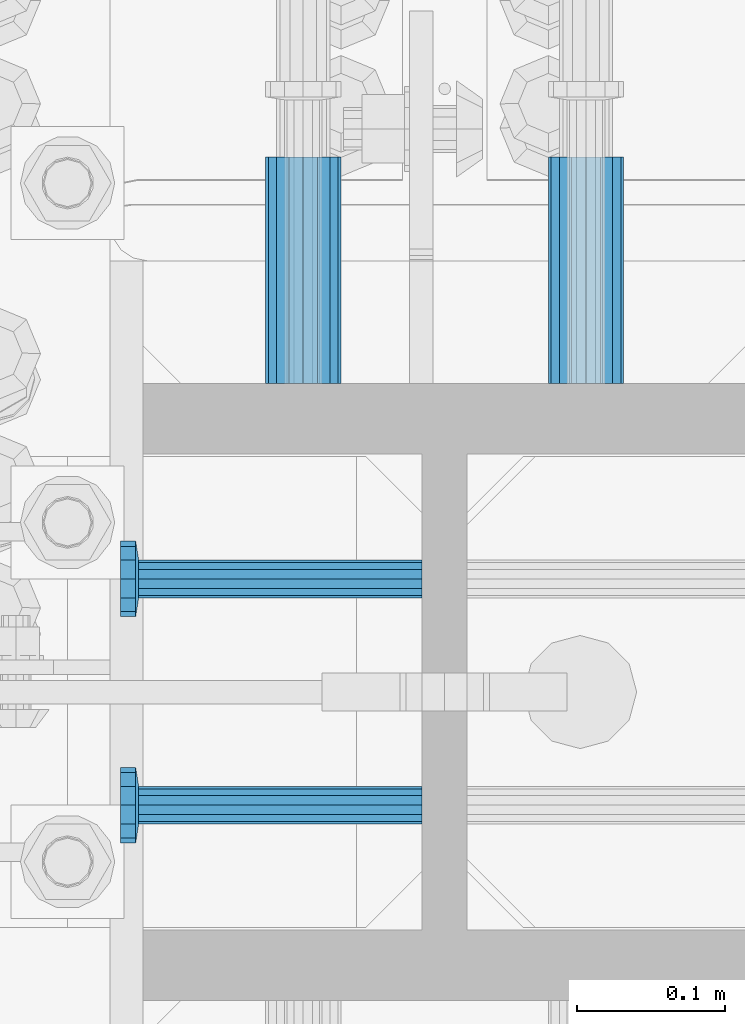
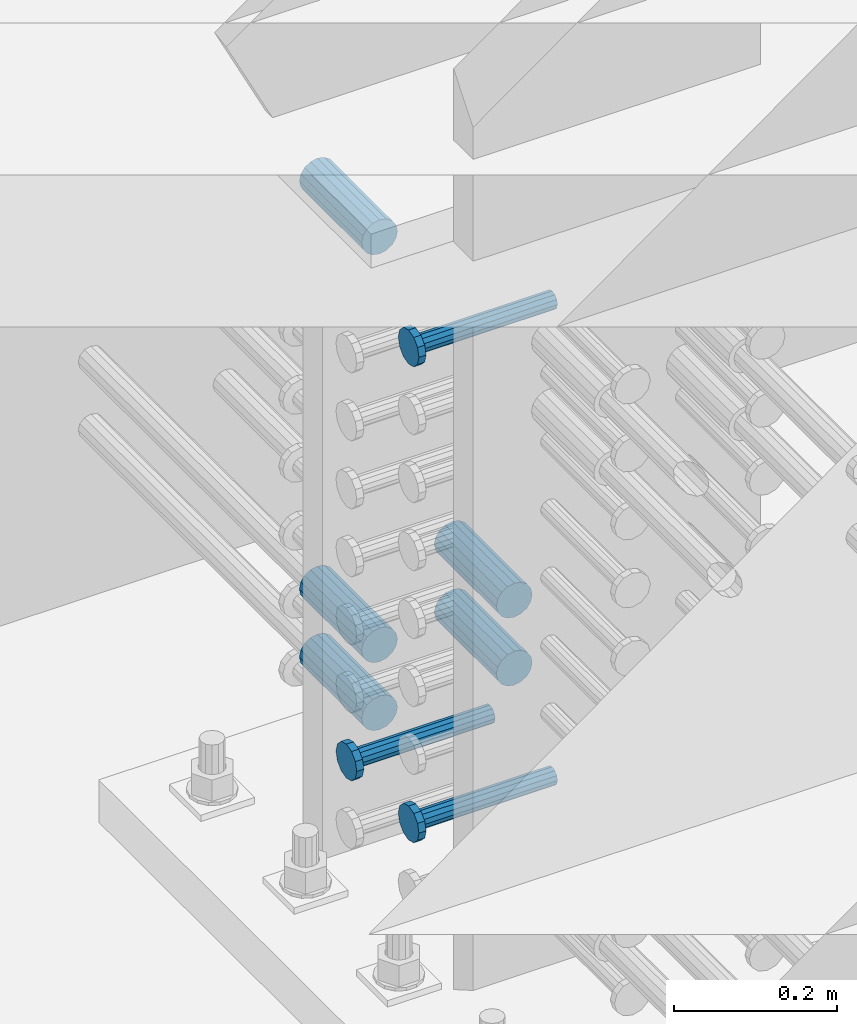
# One storey, part 1291 of 1763: 8 beams, 1 element without a shape of its own.
"""IFC2X3 building model written with IfcOpenShell, lengths in millimetres."""

import ifcopenshell
import ifcopenshell.guid

model = None  # the IFC model being written
_history = None  # IfcOwnerHistory: only IFC2X3 demands one
_inside = {}  # id of a spatial element -> (the spatial element, [elements in it])
_under = {}  # id of a project, library or spatial element -> (it, [spatial elements below it])
_declared = {}  # id of a project -> (the project, [libraries it declares])
_typed = {}  # id of a type object -> (the type object, [elements of that type])
_made_of = {}  # id of a material, layer set ... -> (it, [elements and type objects made of it])


def new_model(schema):
    """Start an empty IFC model of exactly this schema.

    Asked for "IFC4X3", IfcOpenShell would pick the latest addendum, in which some entities
    have other attributes; the version numbers below select the first issue.
    IFC2X3 requires an IfcOwnerHistory on every rooted entity: one is made here for all.
    """
    global model, _history
    if schema == "IFC4X3":
        model = ifcopenshell.file(schema_version=(4, 3, 0, 0))
    else:
        model = ifcopenshell.file(schema=schema)
    _inside.clear()
    _under.clear()
    _declared.clear()
    _typed.clear()
    _made_of.clear()
    _history = None
    if model.schema == "IFC2X3":
        org = make("IfcOrganization", Name="unknown")
        user = make(
            "IfcPersonAndOrganization",
            ThePerson=make("IfcPerson", FamilyName="unknown"),
            TheOrganization=org,
        )
        app = make(
            "IfcApplication",
            ApplicationDeveloper=org,
            Version="unknown",
            ApplicationFullName="unknown",
            ApplicationIdentifier="unknown",
        )
        _history = make(
            "IfcOwnerHistory",
            OwningUser=user,
            OwningApplication=app,
            ChangeAction="ADDED",
            CreationDate=0,
        )
    return model


def make(cls, **values):
    """One entity of the class cls with the attributes given. An attribute that is None is left unset."""
    return model.create_entity(
        cls, **{name: value for name, value in values.items() if value is not None}
    )


def rooted(cls, **values):
    """An entity with a GlobalId (a new one), such as an element, a storey or a relation."""
    return make(cls, GlobalId=ifcopenshell.guid.new(), OwnerHistory=_history, **values)


def si_unit(unit_type, name, prefix=None):
    """IfcSIUnit, for example si_unit("LENGTHUNIT", "METRE", prefix="MILLI")."""
    return make("IfcSIUnit", UnitType=unit_type, Prefix=prefix, Name=name)


def assignment(units):
    """IfcUnitAssignment: the units of a project."""
    return None if units is None else make("IfcUnitAssignment", Units=units)


def point(xyz):
    """IfcCartesianPoint."""
    return None if xyz is None else make("IfcCartesianPoint", Coordinates=xyz)


def direction(xyz):
    """IfcDirection."""
    return None if xyz is None else make("IfcDirection", DirectionRatios=xyz)


def frame(location, z_axis=None, x_axis=None):
    """IfcAxis2Placement3D, a coordinate frame: its origin and axes. An axis left out is left unset."""
    return make(
        "IfcAxis2Placement3D",
        Location=point(location),
        Axis=direction(z_axis),
        RefDirection=direction(x_axis),
    )


def origin_with_axes():
    """The frame at (0, 0, 0) with the z axis (0, 0, 1) and the x axis (1, 0, 0) written out."""
    return frame((0.0, 0.0, 0.0), z_axis=(0.0, 0.0, 1.0), x_axis=(1.0, 0.0, 0.0))


def place(relative_to, where):
    """IfcLocalPlacement: puts the frame where relative to a parent placement (None: the world)."""
    return make(
        "IfcLocalPlacement", PlacementRelTo=relative_to, RelativePlacement=where
    )


def context(
    kind, dimensions, precision=None, world=None, true_north=None, identifier=None
):
    """IfcGeometricRepresentationContext, for example the 3D "Model" context."""
    return make(
        "IfcGeometricRepresentationContext",
        ContextIdentifier=identifier,
        ContextType=kind,
        CoordinateSpaceDimension=dimensions,
        Precision=precision,
        WorldCoordinateSystem=world,
        TrueNorth=true_north,
    )


def subcontext(parent, identifier, kind, view, scale=None):
    """IfcGeometricRepresentationSubContext, for example "Body" below "Model"."""
    return make(
        "IfcGeometricRepresentationSubContext",
        ContextIdentifier=identifier,
        ContextType=kind,
        ParentContext=parent,
        TargetScale=scale,
        TargetView=view,
    )


def project(units=None, contexts=None):
    """IfcProject with its units and contexts."""
    return rooted(
        "IfcProject",
        Name="project",
        RepresentationContexts=contexts,
        UnitsInContext=assignment(units),
    )


def spatial(cls, under=None, at=None, **own):
    """A site, building, storey or space (cls), placed at a placement, below another one or the project."""
    s = rooted(cls, ObjectPlacement=at, **own)
    if under is not None:
        _under.setdefault(under.id(), (under, []))[1].append(s)
    return s


def faces_of(points, faces, orient=None, outer=None):
    """IfcFace entities. A face is a list of loops; a loop is a list of indices into points, from 0.

    orient and outer hold one flag for each loop. By default every Orientation is true, the
    first loop of a face is its IfcFaceOuterBound and the others are IfcFaceBound.
    """
    made = []
    for i, loops in enumerate(faces):
        bounds = []
        for j, loop in enumerate(loops):
            is_outer = j == 0 if outer is None else outer[i][j]
            bounds.append(
                make(
                    "IfcFaceOuterBound" if is_outer else "IfcFaceBound",
                    Bound=make("IfcPolyLoop", Polygon=[points[k] for k in loop]),
                    Orientation=True if orient is None else orient[i][j],
                )
            )
        made.append(make("IfcFace", Bounds=bounds))
    return made


def faceted_brep(points, faces, orient=None, outer=None, voids=None):
    """IfcFacetedBrep: a solid bounded by flat faces; with voids (closed shells), ...WithVoids."""
    shared = [point(p) for p in points]
    hull = make("IfcClosedShell", CfsFaces=faces_of(shared, faces, orient, outer))
    if voids is None:
        return make("IfcFacetedBrep", Outer=hull)
    return make(
        "IfcFacetedBrepWithVoids",
        Outer=hull,
        Voids=[
            make(cls, CfsFaces=faces_of(shared, fs, o, b)) for cls, fs, o, b in voids
        ],
    )


def shape(context_of_items, identifier, shape_type, items):
    """IfcShapeRepresentation: the items that make up one representation, for example the "Body"."""
    return make(
        "IfcShapeRepresentation",
        ContextOfItems=context_of_items,
        RepresentationIdentifier=identifier,
        RepresentationType=shape_type,
        Items=items,
    )


def material(Name=None, Category=None):
    """IfcMaterial."""
    return make("IfcMaterial", Name=Name, Category=Category)


def made_of(thing, what):
    """Note that an element or type object is made of a material, layer set ...; save() writes the relation."""
    if what is not None:
        _made_of.setdefault(what.id(), (what, []))[1].append(thing)
    return thing


def type_object(cls, material=None, **own):
    """A type object (cls), such as IfcWallType, which elements share."""
    return made_of(rooted(cls, **own), material)


def element(
    cls,
    number,
    at=None,
    inside=None,
    cuts=None,
    type_object=None,
    material=None,
    context=None,
    identifier="Body",
    shape_type=None,
    held_by="IfcProductDefinitionShape",
    body=None,
    shapes=None,
    **own,
):
    """One element of the class cls, such as IfcWall. Its Tag is "e" and its number.

    at: its placement. inside: the storey or other place that contains it. cuts: it is an
    opening in that element (IfcRelVoidsElement). A single representation is given by context,
    identifier, shape_type and body (its items); several are given by shapes. held_by: the class
    of the entity that holds the representations. save() writes the other relations.
    """
    e = rooted(cls, Tag="e%d" % number, ObjectPlacement=at, **own)
    if body is not None:
        shapes = [shape(context, identifier, shape_type, body)]
    if shapes is not None:
        e.Representation = make(held_by, Representations=shapes)
    if inside is not None:
        _inside.setdefault(inside.id(), (inside, []))[1].append(e)
    if cuts is not None:
        rooted(
            "IfcRelVoidsElement", RelatingBuildingElement=cuts, RelatedOpeningElement=e
        )
    if type_object is not None:
        _typed.setdefault(type_object.id(), (type_object, []))[1].append(e)
    return made_of(e, material)


def aggregate(whole, parts):
    """IfcRelAggregates: a whole, such as a stair, and the parts it consists of."""
    return rooted("IfcRelAggregates", RelatingObject=whole, RelatedObjects=parts)


def save(model, path):
    """Write the relations noted so far, then the file.

    IfcRelAggregates (storeys below a building ...), IfcRelContainedInSpatialStructure (elements
    in a storey), IfcRelDefinesByType, IfcRelAssociatesMaterial and IfcRelDeclares: one each for
    every whole, place, type object, material and project.
    """
    for whole, parts in _under.values():
        aggregate(whole, parts)
    for where, things in _inside.values():
        rooted(
            "IfcRelContainedInSpatialStructure",
            RelatedElements=things,
            RelatingStructure=where,
        )
    for kind, things in _typed.values():
        rooted("IfcRelDefinesByType", RelatedObjects=things, RelatingType=kind)
    for what, things in _made_of.values():
        rooted("IfcRelAssociatesMaterial", RelatedObjects=things, RelatingMaterial=what)
    for by, libraries in _declared.values():
        rooted("IfcRelDeclares", RelatingContext=by, RelatedDefinitions=libraries)
    model.write(path)


model = new_model("IFC2X3")

# Units and contexts
model_context = context("Model", 3, precision=1e-05, world=origin_with_axes())
body_context = subcontext(model_context, "Body", "Model", "MODEL_VIEW")
ifc_project = project(units=[si_unit("LENGTHUNIT", "METRE", prefix="MILLI"), si_unit("AREAUNIT", "SQUARE_METRE"), si_unit("VOLUMEUNIT", "CUBIC_METRE"), si_unit("MASSUNIT", "GRAM", prefix="KILO"), si_unit("TIMEUNIT", "SECOND"), si_unit("PLANEANGLEUNIT", "RADIAN"), si_unit("SOLIDANGLEUNIT", "STERADIAN"), si_unit("THERMODYNAMICTEMPERATUREUNIT", "DEGREE_CELSIUS"), si_unit("LUMINOUSINTENSITYUNIT", "LUMEN")], contexts=[model_context])

# Site, building, storey
site_placement = place(None, origin_with_axes())
site = spatial("IfcSite", under=ifc_project, at=site_placement, CompositionType="ELEMENT")
building_placement = place(site_placement, origin_with_axes())
building = spatial("IfcBuilding", under=site, at=building_placement, Name="Undefined", CompositionType="ELEMENT")
storey_placement = place(building_placement, origin_with_axes())
storey = spatial("IfcBuildingStorey", under=building, at=storey_placement, Name="Undefined", CompositionType="ELEMENT", Elevation=0.0)

# Assembly, beams
assembly_placement = place(storey_placement, origin_with_axes())
assembly = element("IfcElementAssembly", 1, at=assembly_placement, inside=storey, Name="COLUMN", AssemblyPlace="NOTDEFINED", PredefinedType="RIGID_FRAME")
ifc_material_1 = material(Name="STEEL/A706-GR.80")
beam_type_1 = type_object("IfcBeamType", PredefinedType="NOTDEFINED")
beam_1_placement = place(assembly_placement, frame((-24123.0872736984, -13508.0376828902, 4064.0), z_axis=(0.0, 0.0, 1.0), x_axis=(0.0, 1.0, 0.0)))
beam_1 = element("IfcBeam", 2, at=beam_1_placement, type_object=beam_type_1, material=ifc_material_1, Name="HALF COUPLER F", context=body_context, shape_type="Brep", body=[
    faceted_brep([(32.7659999999996, -8.95349999999962, -15.507916905568), (32.7659999999996, 0.0, -17.9070000000002), (32.7659999999996, 8.95349999999962, -15.507916905568), (32.7659999999996, 15.507916905568, -8.95350000000008), (32.7659999999996, 17.9069999999992, 0.0), (32.7659999999996, 15.507916905568, 8.95350000000008), (32.7659999999996, 8.95349999999962, 15.507916905568), (32.7659999999996, 0.0, 17.9070000000002), (32.7659999999996, -8.95349999999962, 15.507916905568), (32.7659999999996, -15.507916905568, 8.95350000000008), (32.7659999999996, -17.9069999999992, 0.0), (32.7659999999996, -15.507916905568, -8.95350000000008), (152.400103102711, -15.507916905568, 8.95350000000008), (152.400103102711, -8.95349999999962, 15.507916905568), (152.400103102711, -17.9069999999992, 0.0), (152.400103102711, -15.507916905568, -8.95350000000008), (152.400103102711, -8.95349999999962, -15.507916905568), (152.400103102711, 0.0, -17.9070000000002), (152.400103102711, 8.95349999999962, -15.507916905568), (152.400103102711, 15.507916905568, -8.95350000000008), (152.400103102711, 17.9069999999992, 0.0), (152.400103102711, 15.507916905568, 8.95350000000008), (152.400103102711, 8.95349999999962, 15.507916905568), (152.400103102711, 0.0, 17.9070000000002), (0.0, -23.466540125788, 9.72015918207308), (0.0, -17.9605122421381, 17.9605122421385), (0.0, -9.72015918207398, 23.4665401257867), (0.0, 0.0, 25.4000000000001), (0.0, 9.72015918207398, 23.4665401257867), (0.0, 17.9605122421381, 17.9605122421385), (0.0, 23.466540125788, 9.72015918207308), (0.0, 25.4000000000015, 0.0), (0.0, 23.466540125788, -9.72015918207308), (0.0, 17.9605122421381, -17.9605122421385), (0.0, 9.72015918207398, -23.4665401257867), (0.0, 0.0, -25.4000000000001), (0.0, -9.72015918207398, -23.4665401257867), (0.0, -17.9605122421381, -17.9605122421385), (0.0, -23.466540125788, -9.72015918207308), (0.0, -25.4000000000015, 0.0), (152.400103102711, -25.4000000000015, 0.0), (152.400103102711, -23.466540125788, 9.72015918207308), (152.400103102711, -17.9605122421381, 17.9605122421385), (152.400103102711, -9.72015918207398, 23.4665401257867), (152.400103102711, 0.0, 25.4000000000001), (152.400103102711, 9.72015918207398, 23.4665401257867), (152.400103102711, 17.9605122421381, 17.9605122421385), (152.400103102711, 23.466540125788, 9.72015918207308), (152.400103102711, 25.4000000000015, 0.0), (152.400103102711, 23.466540125788, -9.72015918207308), (152.400103102711, 17.9605122421381, -17.9605122421385), (152.400103102711, 9.72015918207398, -23.4665401257867), (152.400103102711, 0.0, -25.4000000000001), (152.400103102711, -9.72015918207398, -23.4665401257867), (152.400103102711, -17.9605122421381, -17.9605122421385), (152.400103102711, -23.466540125788, -9.72015918207308)], [[[0, 1, 2, 3, 4, 5, 6, 7, 8, 9, 10, 11]], [[12, 9, 8, 13]], [[14, 10, 9, 12]], [[15, 11, 10, 14]], [[16, 0, 11, 15]], [[17, 1, 0, 16]], [[18, 2, 1, 17]], [[19, 3, 2, 18]], [[20, 4, 3, 19]], [[21, 5, 4, 20]], [[22, 6, 5, 21]], [[23, 7, 6, 22]], [[13, 8, 7, 23]], [[24, 25, 26, 27, 28, 29, 30, 31, 32, 33, 34, 35, 36, 37, 38, 39]], [[24, 39, 40, 41]], [[25, 24, 41, 42]], [[26, 25, 42, 43]], [[27, 26, 43, 44]], [[28, 27, 44, 45]], [[29, 28, 45, 46]], [[30, 29, 46, 47]], [[31, 30, 47, 48]], [[32, 31, 48, 49]], [[33, 32, 49, 50]], [[34, 33, 50, 51]], [[35, 34, 51, 52]], [[36, 35, 52, 53]], [[37, 36, 53, 54]], [[38, 37, 54, 55]], [[39, 38, 55, 40]], [[54, 53, 52, 51, 50, 49, 48, 47, 46, 45, 44, 43, 42, 41, 40, 55], [21, 20, 19, 18, 17, 16, 15, 14, 12, 13, 23, 22]]]),
])
beam_2_placement = place(assembly_placement, frame((-23932.5872736985, -13508.0377516257, 4064.0), z_axis=(0.0, 0.0, 1.0), x_axis=(0.0, 1.0, 0.0)))
beam_2 = element("IfcBeam", 3, at=beam_2_placement, type_object=beam_type_1, material=ifc_material_1, Name="HALF COUPLER F", context=body_context, shape_type="Brep", body=[
    faceted_brep([(32.7659999999996, -8.95349999999962, -15.507916905568), (32.7659999999996, 0.0, -17.9070000000002), (32.7659999999996, 8.95349999999962, -15.507916905568), (32.7659999999996, 15.507916905568, -8.95350000000008), (32.7659999999996, 17.9069999999992, 0.0), (32.7659999999996, 15.507916905568, 8.95350000000008), (32.7659999999996, 8.95349999999962, 15.507916905568), (32.7659999999996, 0.0, 17.9070000000002), (32.7659999999996, -8.95349999999962, 15.507916905568), (32.7659999999996, -15.507916905568, 8.95350000000008), (32.7659999999996, -17.9069999999992, 0.0), (32.7659999999996, -15.507916905568, -8.95350000000008), (152.400103102711, -15.507916905568, 8.95350000000008), (152.400103102711, -8.95349999999962, 15.507916905568), (152.400103102711, -17.9069999999992, 0.0), (152.400103102711, -15.507916905568, -8.95350000000008), (152.400103102711, -8.95349999999962, -15.507916905568), (152.400103102711, 0.0, -17.9070000000002), (152.400103102711, 8.95349999999962, -15.507916905568), (152.400103102711, 15.507916905568, -8.95350000000008), (152.400103102711, 17.9069999999992, 0.0), (152.400103102711, 15.507916905568, 8.95350000000008), (152.400103102711, 8.95349999999962, 15.507916905568), (152.400103102711, 0.0, 17.9070000000002), (0.0, -23.466540125788, 9.72015918207308), (0.0, -17.9605122421381, 17.9605122421385), (0.0, -9.72015918207398, 23.4665401257867), (0.0, 0.0, 25.4000000000001), (0.0, 9.72015918207398, 23.4665401257867), (0.0, 17.9605122421381, 17.9605122421385), (0.0, 23.466540125788, 9.72015918207308), (0.0, 25.4000000000015, 0.0), (0.0, 23.466540125788, -9.72015918207308), (0.0, 17.9605122421381, -17.9605122421385), (0.0, 9.72015918207398, -23.4665401257867), (0.0, 0.0, -25.4000000000001), (0.0, -9.72015918207398, -23.4665401257867), (0.0, -17.9605122421381, -17.9605122421385), (0.0, -23.466540125788, -9.72015918207308), (0.0, -25.4000000000015, 0.0), (152.400103102711, -25.4000000000015, 0.0), (152.400103102711, -23.466540125788, 9.72015918207308), (152.400103102711, -17.9605122421381, 17.9605122421385), (152.400103102711, -9.72015918207398, 23.4665401257867), (152.400103102711, 0.0, 25.4000000000001), (152.400103102711, 9.72015918207398, 23.4665401257867), (152.400103102711, 17.9605122421381, 17.9605122421385), (152.400103102711, 23.466540125788, 9.72015918207308), (152.400103102711, 25.4000000000015, 0.0), (152.400103102711, 23.466540125788, -9.72015918207308), (152.400103102711, 17.9605122421381, -17.9605122421385), (152.400103102711, 9.72015918207398, -23.4665401257867), (152.400103102711, 0.0, -25.4000000000001), (152.400103102711, -9.72015918207398, -23.4665401257867), (152.400103102711, -17.9605122421381, -17.9605122421385), (152.400103102711, -23.466540125788, -9.72015918207308)], [[[0, 1, 2, 3, 4, 5, 6, 7, 8, 9, 10, 11]], [[12, 9, 8, 13]], [[14, 10, 9, 12]], [[15, 11, 10, 14]], [[16, 0, 11, 15]], [[17, 1, 0, 16]], [[18, 2, 1, 17]], [[19, 3, 2, 18]], [[20, 4, 3, 19]], [[21, 5, 4, 20]], [[22, 6, 5, 21]], [[23, 7, 6, 22]], [[13, 8, 7, 23]], [[24, 25, 26, 27, 28, 29, 30, 31, 32, 33, 34, 35, 36, 37, 38, 39]], [[24, 39, 40, 41]], [[25, 24, 41, 42]], [[26, 25, 42, 43]], [[27, 26, 43, 44]], [[28, 27, 44, 45]], [[29, 28, 45, 46]], [[30, 29, 46, 47]], [[31, 30, 47, 48]], [[32, 31, 48, 49]], [[33, 32, 49, 50]], [[34, 33, 50, 51]], [[35, 34, 51, 52]], [[36, 35, 52, 53]], [[37, 36, 53, 54]], [[38, 37, 54, 55]], [[39, 38, 55, 40]], [[54, 53, 52, 51, 50, 49, 48, 47, 46, 45, 44, 43, 42, 41, 40, 55], [21, 20, 19, 18, 17, 16, 15, 14, 12, 13, 23, 22]]]),
])
beam_3_placement = place(assembly_placement, frame((-24123.0872736984, -13508.0376828902, 4165.6), z_axis=(0.0, 0.0, 1.0), x_axis=(0.0, 1.0, 0.0)))
beam_3 = element("IfcBeam", 4, at=beam_3_placement, type_object=beam_type_1, material=ifc_material_1, Name="HALF COUPLER F", context=body_context, shape_type="Brep", body=[
    faceted_brep([(32.7659999999996, -8.95349999999962, -15.507916905568), (32.7659999999996, 0.0, -17.9070000000002), (32.7659999999996, 8.95349999999962, -15.507916905568), (32.7659999999996, 15.507916905568, -8.95350000000008), (32.7659999999996, 17.9069999999992, 0.0), (32.7659999999996, 15.507916905568, 8.95350000000008), (32.7659999999996, 8.95349999999962, 15.507916905568), (32.7659999999996, 0.0, 17.9070000000002), (32.7659999999996, -8.95349999999962, 15.507916905568), (32.7659999999996, -15.507916905568, 8.95350000000008), (32.7659999999996, -17.9069999999992, 0.0), (32.7659999999996, -15.507916905568, -8.95350000000008), (152.400103102711, -15.507916905568, 8.95350000000008), (152.400103102711, -8.95349999999962, 15.507916905568), (152.400103102711, -17.9069999999992, 0.0), (152.400103102711, -15.507916905568, -8.95350000000008), (152.400103102711, -8.95349999999962, -15.507916905568), (152.400103102711, 0.0, -17.9070000000002), (152.400103102711, 8.95349999999962, -15.507916905568), (152.400103102711, 15.507916905568, -8.95350000000008), (152.400103102711, 17.9069999999992, 0.0), (152.400103102711, 15.507916905568, 8.95350000000008), (152.400103102711, 8.95349999999962, 15.507916905568), (152.400103102711, 0.0, 17.9070000000002), (0.0, -23.466540125788, 9.72015918207308), (0.0, -17.9605122421381, 17.9605122421385), (0.0, -9.72015918207398, 23.4665401257867), (0.0, 0.0, 25.4000000000001), (0.0, 9.72015918207398, 23.4665401257867), (0.0, 17.9605122421381, 17.9605122421385), (0.0, 23.466540125788, 9.72015918207308), (0.0, 25.4000000000015, 0.0), (0.0, 23.466540125788, -9.72015918207308), (0.0, 17.9605122421381, -17.9605122421385), (0.0, 9.72015918207398, -23.4665401257867), (0.0, 0.0, -25.4000000000001), (0.0, -9.72015918207398, -23.4665401257867), (0.0, -17.9605122421381, -17.9605122421385), (0.0, -23.466540125788, -9.72015918207308), (0.0, -25.4000000000015, 0.0), (152.400103102711, -25.4000000000015, 0.0), (152.400103102711, -23.466540125788, 9.72015918207308), (152.400103102711, -17.9605122421381, 17.9605122421385), (152.400103102711, -9.72015918207398, 23.4665401257867), (152.400103102711, 0.0, 25.4000000000001), (152.400103102711, 9.72015918207398, 23.4665401257867), (152.400103102711, 17.9605122421381, 17.9605122421385), (152.400103102711, 23.466540125788, 9.72015918207308), (152.400103102711, 25.4000000000015, 0.0), (152.400103102711, 23.466540125788, -9.72015918207308), (152.400103102711, 17.9605122421381, -17.9605122421385), (152.400103102711, 9.72015918207398, -23.4665401257867), (152.400103102711, 0.0, -25.4000000000001), (152.400103102711, -9.72015918207398, -23.4665401257867), (152.400103102711, -17.9605122421381, -17.9605122421385), (152.400103102711, -23.466540125788, -9.72015918207308)], [[[0, 1, 2, 3, 4, 5, 6, 7, 8, 9, 10, 11]], [[12, 9, 8, 13]], [[14, 10, 9, 12]], [[15, 11, 10, 14]], [[16, 0, 11, 15]], [[17, 1, 0, 16]], [[18, 2, 1, 17]], [[19, 3, 2, 18]], [[20, 4, 3, 19]], [[21, 5, 4, 20]], [[22, 6, 5, 21]], [[23, 7, 6, 22]], [[13, 8, 7, 23]], [[24, 25, 26, 27, 28, 29, 30, 31, 32, 33, 34, 35, 36, 37, 38, 39]], [[24, 39, 40, 41]], [[25, 24, 41, 42]], [[26, 25, 42, 43]], [[27, 26, 43, 44]], [[28, 27, 44, 45]], [[29, 28, 45, 46]], [[30, 29, 46, 47]], [[31, 30, 47, 48]], [[32, 31, 48, 49]], [[33, 32, 49, 50]], [[34, 33, 50, 51]], [[35, 34, 51, 52]], [[36, 35, 52, 53]], [[37, 36, 53, 54]], [[38, 37, 54, 55]], [[39, 38, 55, 40]], [[54, 53, 52, 51, 50, 49, 48, 47, 46, 45, 44, 43, 42, 41, 40, 55], [21, 20, 19, 18, 17, 16, 15, 14, 12, 13, 23, 22]]]),
])
beam_4_placement = place(assembly_placement, frame((-23932.5872736985, -13508.0377516257, 4165.6), z_axis=(0.0, 0.0, 1.0), x_axis=(0.0, 1.0, 0.0)))
beam_4 = element("IfcBeam", 5, at=beam_4_placement, type_object=beam_type_1, material=ifc_material_1, Name="HALF COUPLER F", context=body_context, shape_type="Brep", body=[
    faceted_brep([(32.7659999999996, -8.95349999999962, -15.507916905568), (32.7659999999996, 0.0, -17.9070000000002), (32.7659999999996, 8.95349999999962, -15.507916905568), (32.7659999999996, 15.507916905568, -8.95350000000008), (32.7659999999996, 17.9069999999992, 0.0), (32.7659999999996, 15.507916905568, 8.95350000000008), (32.7659999999996, 8.95349999999962, 15.507916905568), (32.7659999999996, 0.0, 17.9070000000002), (32.7659999999996, -8.95349999999962, 15.507916905568), (32.7659999999996, -15.507916905568, 8.95350000000008), (32.7659999999996, -17.9069999999992, 0.0), (32.7659999999996, -15.507916905568, -8.95350000000008), (152.400103102711, -15.507916905568, 8.95350000000008), (152.400103102711, -8.95349999999962, 15.507916905568), (152.400103102711, -17.9069999999992, 0.0), (152.400103102711, -15.507916905568, -8.95350000000008), (152.400103102711, -8.95349999999962, -15.507916905568), (152.400103102711, 0.0, -17.9070000000002), (152.400103102711, 8.95349999999962, -15.507916905568), (152.400103102711, 15.507916905568, -8.95350000000008), (152.400103102711, 17.9069999999992, 0.0), (152.400103102711, 15.507916905568, 8.95350000000008), (152.400103102711, 8.95349999999962, 15.507916905568), (152.400103102711, 0.0, 17.9070000000002), (0.0, -23.466540125788, 9.72015918207308), (0.0, -17.9605122421381, 17.9605122421385), (0.0, -9.72015918207398, 23.4665401257867), (0.0, 0.0, 25.4000000000001), (0.0, 9.72015918207398, 23.4665401257867), (0.0, 17.9605122421381, 17.9605122421385), (0.0, 23.466540125788, 9.72015918207308), (0.0, 25.4000000000015, 0.0), (0.0, 23.466540125788, -9.72015918207308), (0.0, 17.9605122421381, -17.9605122421385), (0.0, 9.72015918207398, -23.4665401257867), (0.0, 0.0, -25.4000000000001), (0.0, -9.72015918207398, -23.4665401257867), (0.0, -17.9605122421381, -17.9605122421385), (0.0, -23.466540125788, -9.72015918207308), (0.0, -25.4000000000015, 0.0), (152.400103102711, -25.4000000000015, 0.0), (152.400103102711, -23.466540125788, 9.72015918207308), (152.400103102711, -17.9605122421381, 17.9605122421385), (152.400103102711, -9.72015918207398, 23.4665401257867), (152.400103102711, 0.0, 25.4000000000001), (152.400103102711, 9.72015918207398, 23.4665401257867), (152.400103102711, 17.9605122421381, 17.9605122421385), (152.400103102711, 23.466540125788, 9.72015918207308), (152.400103102711, 25.4000000000015, 0.0), (152.400103102711, 23.466540125788, -9.72015918207308), (152.400103102711, 17.9605122421381, -17.9605122421385), (152.400103102711, 9.72015918207398, -23.4665401257867), (152.400103102711, 0.0, -25.4000000000001), (152.400103102711, -9.72015918207398, -23.4665401257867), (152.400103102711, -17.9605122421381, -17.9605122421385), (152.400103102711, -23.466540125788, -9.72015918207308)], [[[0, 1, 2, 3, 4, 5, 6, 7, 8, 9, 10, 11]], [[12, 9, 8, 13]], [[14, 10, 9, 12]], [[15, 11, 10, 14]], [[16, 0, 11, 15]], [[17, 1, 0, 16]], [[18, 2, 1, 17]], [[19, 3, 2, 18]], [[20, 4, 3, 19]], [[21, 5, 4, 20]], [[22, 6, 5, 21]], [[23, 7, 6, 22]], [[13, 8, 7, 23]], [[24, 25, 26, 27, 28, 29, 30, 31, 32, 33, 34, 35, 36, 37, 38, 39]], [[24, 39, 40, 41]], [[25, 24, 41, 42]], [[26, 25, 42, 43]], [[27, 26, 43, 44]], [[28, 27, 44, 45]], [[29, 28, 45, 46]], [[30, 29, 46, 47]], [[31, 30, 47, 48]], [[32, 31, 48, 49]], [[33, 32, 49, 50]], [[34, 33, 50, 51]], [[35, 34, 51, 52]], [[36, 35, 52, 53]], [[37, 36, 53, 54]], [[38, 37, 54, 55]], [[39, 38, 55, 40]], [[54, 53, 52, 51, 50, 49, 48, 47, 46, 45, 44, 43, 42, 41, 40, 55], [21, 20, 19, 18, 17, 16, 15, 14, 12, 13, 23, 22]]]),
])
beam_5_placement = place(assembly_placement, frame((-24123.0872736984, -13508.0375454197, 4775.20000000009), z_axis=(0.0, 0.0, 1.0), x_axis=(0.0, 1.0, 0.0)))
beam_5 = element("IfcBeam", 6, at=beam_5_placement, type_object=beam_type_1, material=ifc_material_1, Name="HALF COUPLER F", context=body_context, shape_type="Brep", body=[
    faceted_brep([(32.7659999999996, -8.95349999999962, -15.507916905568), (32.7659999999996, 0.0, -17.9070000000002), (32.7659999999996, 8.95349999999962, -15.507916905568), (32.7659999999996, 15.507916905568, -8.95350000000008), (32.7659999999996, 17.9069999999992, 0.0), (32.7659999999996, 15.507916905568, 8.95350000000008), (32.7659999999996, 8.95349999999962, 15.507916905568), (32.7659999999996, 0.0, 17.9070000000002), (32.7659999999996, -8.95349999999962, 15.507916905568), (32.7659999999996, -15.507916905568, 8.95350000000008), (32.7659999999996, -17.9069999999992, 0.0), (32.7659999999996, -15.507916905568, -8.95350000000008), (152.400103102711, -15.507916905568, 8.95350000000008), (152.400103102711, -8.95349999999962, 15.507916905568), (152.400103102711, -17.9069999999992, 0.0), (152.400103102711, -15.507916905568, -8.95350000000008), (152.400103102711, -8.95349999999962, -15.507916905568), (152.400103102711, 0.0, -17.9070000000002), (152.400103102711, 8.95349999999962, -15.507916905568), (152.400103102711, 15.507916905568, -8.95350000000008), (152.400103102711, 17.9069999999992, 0.0), (152.400103102711, 15.507916905568, 8.95350000000008), (152.400103102711, 8.95349999999962, 15.507916905568), (152.400103102711, 0.0, 17.9070000000002), (0.0, -23.466540125788, 9.72015918207308), (0.0, -17.9605122421381, 17.9605122421385), (0.0, -9.72015918207398, 23.4665401257867), (0.0, 0.0, 25.4000000000001), (0.0, 9.72015918207398, 23.4665401257867), (0.0, 17.9605122421381, 17.9605122421385), (0.0, 23.466540125788, 9.72015918207308), (0.0, 25.4000000000015, 0.0), (0.0, 23.466540125788, -9.72015918207308), (0.0, 17.9605122421381, -17.9605122421385), (0.0, 9.72015918207398, -23.4665401257867), (0.0, 0.0, -25.4000000000001), (0.0, -9.72015918207398, -23.4665401257867), (0.0, -17.9605122421381, -17.9605122421385), (0.0, -23.466540125788, -9.72015918207308), (0.0, -25.4000000000015, 0.0), (152.400103102711, -25.4000000000015, 0.0), (152.400103102711, -23.466540125788, 9.72015918207308), (152.400103102711, -17.9605122421381, 17.9605122421385), (152.400103102711, -9.72015918207398, 23.4665401257867), (152.400103102711, 0.0, 25.4000000000001), (152.400103102711, 9.72015918207398, 23.4665401257867), (152.400103102711, 17.9605122421381, 17.9605122421385), (152.400103102711, 23.466540125788, 9.72015918207308), (152.400103102711, 25.4000000000015, 0.0), (152.400103102711, 23.466540125788, -9.72015918207308), (152.400103102711, 17.9605122421381, -17.9605122421385), (152.400103102711, 9.72015918207398, -23.4665401257867), (152.400103102711, 0.0, -25.4000000000001), (152.400103102711, -9.72015918207398, -23.4665401257867), (152.400103102711, -17.9605122421381, -17.9605122421385), (152.400103102711, -23.466540125788, -9.72015918207308)], [[[0, 1, 2, 3, 4, 5, 6, 7, 8, 9, 10, 11]], [[12, 9, 8, 13]], [[14, 10, 9, 12]], [[15, 11, 10, 14]], [[16, 0, 11, 15]], [[17, 1, 0, 16]], [[18, 2, 1, 17]], [[19, 3, 2, 18]], [[20, 4, 3, 19]], [[21, 5, 4, 20]], [[22, 6, 5, 21]], [[23, 7, 6, 22]], [[13, 8, 7, 23]], [[24, 25, 26, 27, 28, 29, 30, 31, 32, 33, 34, 35, 36, 37, 38, 39]], [[24, 39, 40, 41]], [[25, 24, 41, 42]], [[26, 25, 42, 43]], [[27, 26, 43, 44]], [[28, 27, 44, 45]], [[29, 28, 45, 46]], [[30, 29, 46, 47]], [[31, 30, 47, 48]], [[32, 31, 48, 49]], [[33, 32, 49, 50]], [[34, 33, 50, 51]], [[35, 34, 51, 52]], [[36, 35, 52, 53]], [[37, 36, 53, 54]], [[38, 37, 54, 55]], [[39, 38, 55, 40]], [[54, 53, 52, 51, 50, 49, 48, 47, 46, 45, 44, 43, 42, 41, 40, 55], [21, 20, 19, 18, 17, 16, 15, 14, 12, 13, 23, 22]]]),
])
ifc_material_2 = material(Name="STEEL/A108")
beam_type_2 = type_object("IfcBeamType", PredefinedType="NOTDEFINED")
beam_6_placement = place(assembly_placement, frame((-24042.9185298019, -13792.1999316062, 4826.00000000008), z_axis=(0.0, -1.0, 0.0), x_axis=(-1.0, 0.0, 0.0)))
beam_6 = element("IfcBeam", 7, at=beam_6_placement, type_object=beam_type_2, material=ifc_material_2, Name="HEADED STUD ANCHOR", context=body_context, shape_type="Brep", body=[
    faceted_brep([(0.0, -12.6999999999971, -1.81898940354586e-12), (3.63797880709171e-12, -11.0, -6.34999990463257), (191.00799999576, -11.0, -6.34999990454889), (191.007999995752, -12.6999998092651, 8.36735125631094e-11), (7.27595761418343e-12, -6.34999990463257, -11.0), (191.00799999576, -6.34999990463257, -10.9999999999163), (3.63797880709171e-12, 0.0, -12.6999998092651), (191.00799999576, 0.0, -12.6999998091815), (7.27595761418343e-12, 6.34999990463257, -11.0), (191.00799999576, 6.34999990463257, -10.9999999999163), (3.63797880709171e-12, 11.0, -6.34999990463257), (191.00799999576, 11.0, -6.34999990454889), (0.0, 12.6999999999971, -1.81898940354586e-12), (191.007999995752, 12.6999998092651, 8.36735125631094e-11), (0.0, 11.0, 6.34999990463257), (191.007999995752, 11.0, 6.34999990471624), (-3.63797880709171e-12, 6.34999990463257, 11.0), (191.007999995749, 6.34999990463257, 11.0000000000837), (-3.63797880709171e-12, 0.0, 12.6999998092651), (191.007999995749, 0.0, 12.6999998093488), (-3.63797880709171e-12, -6.34999990463257, 11.0), (191.007999995749, -6.34999990463257, 11.0000000000837), (0.0, -11.0, 6.34999990463257), (191.007999995752, -11.0, 6.34999990471624), (193.039999995715, -22.0, -12.6999998091796), (193.039999995708, -25.3999996185303, 8.54925019666553e-11), (193.039999995719, -12.6999998092651, -21.9999999999145), (193.039999995719, 0.0, -25.3999996184448), (193.039999995719, 12.6999998092651, -21.9999999999145), (193.039999995715, 22.0, -12.6999998091796), (193.039999995708, 25.3999996185303, 8.54925019666553e-11), (193.039999995704, 22.0, 12.6999998093506), (193.039999995701, 12.6999998092651, 22.0000000000855), (193.039999995697, 0.0, 25.3999996186158), (193.039999995701, -12.6999998092651, 22.0000000000855), (193.039999995704, -22.0, 12.6999998093506), (203.199999995486, -22.0, -12.6999998091742), (203.199999995482, -25.3999996185303, 9.09494701772928e-11), (203.199999995493, -12.6999998092651, -21.9999999999091), (203.199999995493, 0.0, -25.3999996184393), (203.199999995493, 12.6999998092651, -21.9999999999091), (203.199999995486, 22.0, -12.6999998091742), (203.199999995482, 25.3999996185303, 9.09494701772928e-11), (203.199999995479, 22.0, 12.6999998093561), (203.199999995475, 12.6999998092651, 22.0000000000909), (203.199999995471, 0.0, 25.3999996186212), (203.199999995475, -12.6999998092651, 22.0000000000909), (203.199999995479, -22.0, 12.6999998093561)], [[[0, 1, 2, 3]], [[1, 4, 5, 2]], [[4, 6, 7, 5]], [[6, 8, 9, 7]], [[8, 10, 11, 9]], [[10, 12, 13, 11]], [[12, 14, 15, 13]], [[14, 16, 17, 15]], [[16, 18, 19, 17]], [[18, 20, 21, 19]], [[20, 22, 23, 21]], [[22, 0, 3, 23]], [[22, 20, 18, 16, 14, 12, 10, 8, 6, 4, 1, 0]], [[3, 2, 24, 25]], [[2, 5, 26, 24]], [[5, 7, 27, 26]], [[7, 9, 28, 27]], [[9, 11, 29, 28]], [[11, 13, 30, 29]], [[13, 15, 31, 30]], [[15, 17, 32, 31]], [[17, 19, 33, 32]], [[19, 21, 34, 33]], [[21, 23, 35, 34]], [[23, 3, 25, 35]], [[25, 24, 36, 37]], [[24, 26, 38, 36]], [[26, 27, 39, 38]], [[27, 28, 40, 39]], [[28, 29, 41, 40]], [[29, 30, 42, 41]], [[30, 31, 43, 42]], [[31, 32, 44, 43]], [[32, 33, 45, 44]], [[33, 34, 46, 45]], [[34, 35, 47, 46]], [[35, 25, 37, 47]], [[38, 39, 40, 41, 42, 43, 44, 45, 46, 47, 37, 36]]]),
])
beam_7_placement = place(assembly_placement, frame((-24042.9185299162, -13639.7999316071, 4114.80000000004), z_axis=(0.0, -1.0, 0.0), x_axis=(-1.0, 0.0, 0.0)))
beam_7 = element("IfcBeam", 8, at=beam_7_placement, type_object=beam_type_2, material=ifc_material_2, Name="HEADED STUD ANCHOR", context=body_context, shape_type="Brep", body=[
    faceted_brep([(0.0, -12.6999999999971, -1.81898940354586e-12), (3.63797880709171e-12, -11.0, -6.34999990463257), (191.00799999576, -11.0, -6.34999990454889), (191.007999995752, -12.6999998092651, 8.36735125631094e-11), (7.27595761418343e-12, -6.34999990463257, -11.0), (191.00799999576, -6.34999990463257, -10.9999999999163), (3.63797880709171e-12, 0.0, -12.6999998092651), (191.00799999576, 0.0, -12.6999998091815), (7.27595761418343e-12, 6.34999990463257, -11.0), (191.00799999576, 6.34999990463257, -10.9999999999163), (3.63797880709171e-12, 11.0, -6.34999990463257), (191.00799999576, 11.0, -6.34999990454889), (0.0, 12.6999999999971, -1.81898940354586e-12), (191.007999995752, 12.6999998092651, 8.36735125631094e-11), (0.0, 11.0, 6.34999990463257), (191.007999995752, 11.0, 6.34999990471624), (-3.63797880709171e-12, 6.34999990463257, 11.0), (191.007999995749, 6.34999990463257, 11.0000000000837), (-3.63797880709171e-12, 0.0, 12.6999998092651), (191.007999995749, 0.0, 12.6999998093488), (-3.63797880709171e-12, -6.34999990463257, 11.0), (191.007999995749, -6.34999990463257, 11.0000000000837), (0.0, -11.0, 6.34999990463257), (191.007999995752, -11.0, 6.34999990471624), (193.039999995715, -22.0, -12.6999998091796), (193.039999995708, -25.3999996185303, 8.54925019666553e-11), (193.039999995719, -12.6999998092651, -21.9999999999145), (193.039999995719, 0.0, -25.3999996184448), (193.039999995719, 12.6999998092651, -21.9999999999145), (193.039999995715, 22.0, -12.6999998091796), (193.039999995708, 25.3999996185303, 8.54925019666553e-11), (193.039999995704, 22.0, 12.6999998093506), (193.039999995701, 12.6999998092651, 22.0000000000855), (193.039999995697, 0.0, 25.3999996186158), (193.039999995701, -12.6999998092651, 22.0000000000855), (193.039999995704, -22.0, 12.6999998093506), (203.199999995486, -22.0, -12.6999998091742), (203.199999995482, -25.3999996185303, 9.09494701772928e-11), (203.199999995493, -12.6999998092651, -21.9999999999091), (203.199999995493, 0.0, -25.3999996184393), (203.199999995493, 12.6999998092651, -21.9999999999091), (203.199999995486, 22.0, -12.6999998091742), (203.199999995482, 25.3999996185303, 9.09494701772928e-11), (203.199999995479, 22.0, 12.6999998093561), (203.199999995475, 12.6999998092651, 22.0000000000909), (203.199999995471, 0.0, 25.3999996186212), (203.199999995475, -12.6999998092651, 22.0000000000909), (203.199999995479, -22.0, 12.6999998093561)], [[[0, 1, 2, 3]], [[1, 4, 5, 2]], [[4, 6, 7, 5]], [[6, 8, 9, 7]], [[8, 10, 11, 9]], [[10, 12, 13, 11]], [[12, 14, 15, 13]], [[14, 16, 17, 15]], [[16, 18, 19, 17]], [[18, 20, 21, 19]], [[20, 22, 23, 21]], [[22, 0, 3, 23]], [[22, 20, 18, 16, 14, 12, 10, 8, 6, 4, 1, 0]], [[3, 2, 24, 25]], [[2, 5, 26, 24]], [[5, 7, 27, 26]], [[7, 9, 28, 27]], [[9, 11, 29, 28]], [[11, 13, 30, 29]], [[13, 15, 31, 30]], [[15, 17, 32, 31]], [[17, 19, 33, 32]], [[19, 21, 34, 33]], [[21, 23, 35, 34]], [[23, 3, 25, 35]], [[25, 24, 36, 37]], [[24, 26, 38, 36]], [[26, 27, 39, 38]], [[27, 28, 40, 39]], [[28, 29, 41, 40]], [[29, 30, 42, 41]], [[30, 31, 43, 42]], [[31, 32, 44, 43]], [[32, 33, 45, 44]], [[33, 34, 46, 45]], [[34, 35, 47, 46]], [[35, 25, 37, 47]], [[38, 39, 40, 41, 42, 43, 44, 45, 46, 47, 37, 36]]]),
])
beam_8_placement = place(assembly_placement, frame((-24042.9185298019, -13792.1999316062, 4114.80000000004), z_axis=(0.0, -1.0, 0.0), x_axis=(-1.0, 0.0, 0.0)))
beam_8 = element("IfcBeam", 9, at=beam_8_placement, type_object=beam_type_2, material=ifc_material_2, Name="HEADED STUD ANCHOR", context=body_context, shape_type="Brep", body=[
    faceted_brep([(0.0, -12.6999999999971, -1.81898940354586e-12), (3.63797880709171e-12, -11.0, -6.34999990463257), (191.00799999576, -11.0, -6.34999990454889), (191.007999995752, -12.6999998092651, 8.36735125631094e-11), (7.27595761418343e-12, -6.34999990463257, -11.0), (191.00799999576, -6.34999990463257, -10.9999999999163), (3.63797880709171e-12, 0.0, -12.6999998092651), (191.00799999576, 0.0, -12.6999998091815), (7.27595761418343e-12, 6.34999990463257, -11.0), (191.00799999576, 6.34999990463257, -10.9999999999163), (3.63797880709171e-12, 11.0, -6.34999990463257), (191.00799999576, 11.0, -6.34999990454889), (0.0, 12.6999999999971, -1.81898940354586e-12), (191.007999995752, 12.6999998092651, 8.36735125631094e-11), (0.0, 11.0, 6.34999990463257), (191.007999995752, 11.0, 6.34999990471624), (-3.63797880709171e-12, 6.34999990463257, 11.0), (191.007999995749, 6.34999990463257, 11.0000000000837), (-3.63797880709171e-12, 0.0, 12.6999998092651), (191.007999995749, 0.0, 12.6999998093488), (-3.63797880709171e-12, -6.34999990463257, 11.0), (191.007999995749, -6.34999990463257, 11.0000000000837), (0.0, -11.0, 6.34999990463257), (191.007999995752, -11.0, 6.34999990471624), (193.039999995715, -22.0, -12.6999998091796), (193.039999995708, -25.3999996185303, 8.54925019666553e-11), (193.039999995719, -12.6999998092651, -21.9999999999145), (193.039999995719, 0.0, -25.3999996184448), (193.039999995719, 12.6999998092651, -21.9999999999145), (193.039999995715, 22.0, -12.6999998091796), (193.039999995708, 25.3999996185303, 8.54925019666553e-11), (193.039999995704, 22.0, 12.6999998093506), (193.039999995701, 12.6999998092651, 22.0000000000855), (193.039999995697, 0.0, 25.3999996186158), (193.039999995701, -12.6999998092651, 22.0000000000855), (193.039999995704, -22.0, 12.6999998093506), (203.199999995486, -22.0, -12.6999998091742), (203.199999995482, -25.3999996185303, 9.09494701772928e-11), (203.199999995493, -12.6999998092651, -21.9999999999091), (203.199999995493, 0.0, -25.3999996184393), (203.199999995493, 12.6999998092651, -21.9999999999091), (203.199999995486, 22.0, -12.6999998091742), (203.199999995482, 25.3999996185303, 9.09494701772928e-11), (203.199999995479, 22.0, 12.6999998093561), (203.199999995475, 12.6999998092651, 22.0000000000909), (203.199999995471, 0.0, 25.3999996186212), (203.199999995475, -12.6999998092651, 22.0000000000909), (203.199999995479, -22.0, 12.6999998093561)], [[[0, 1, 2, 3]], [[1, 4, 5, 2]], [[4, 6, 7, 5]], [[6, 8, 9, 7]], [[8, 10, 11, 9]], [[10, 12, 13, 11]], [[12, 14, 15, 13]], [[14, 16, 17, 15]], [[16, 18, 19, 17]], [[18, 20, 21, 19]], [[20, 22, 23, 21]], [[22, 0, 3, 23]], [[22, 20, 18, 16, 14, 12, 10, 8, 6, 4, 1, 0]], [[3, 2, 24, 25]], [[2, 5, 26, 24]], [[5, 7, 27, 26]], [[7, 9, 28, 27]], [[9, 11, 29, 28]], [[11, 13, 30, 29]], [[13, 15, 31, 30]], [[15, 17, 32, 31]], [[17, 19, 33, 32]], [[19, 21, 34, 33]], [[21, 23, 35, 34]], [[23, 3, 25, 35]], [[25, 24, 36, 37]], [[24, 26, 38, 36]], [[26, 27, 39, 38]], [[27, 28, 40, 39]], [[28, 29, 41, 40]], [[29, 30, 42, 41]], [[30, 31, 43, 42]], [[31, 32, 44, 43]], [[32, 33, 45, 44]], [[33, 34, 46, 45]], [[34, 35, 47, 46]], [[35, 25, 37, 47]], [[38, 39, 40, 41, 42, 43, 44, 45, 46, 47, 37, 36]]]),
])
aggregate(assembly, [beam_6, beam_7, beam_8, beam_1, beam_2, beam_3, beam_4, beam_5])

save(model, "model.ifc")
